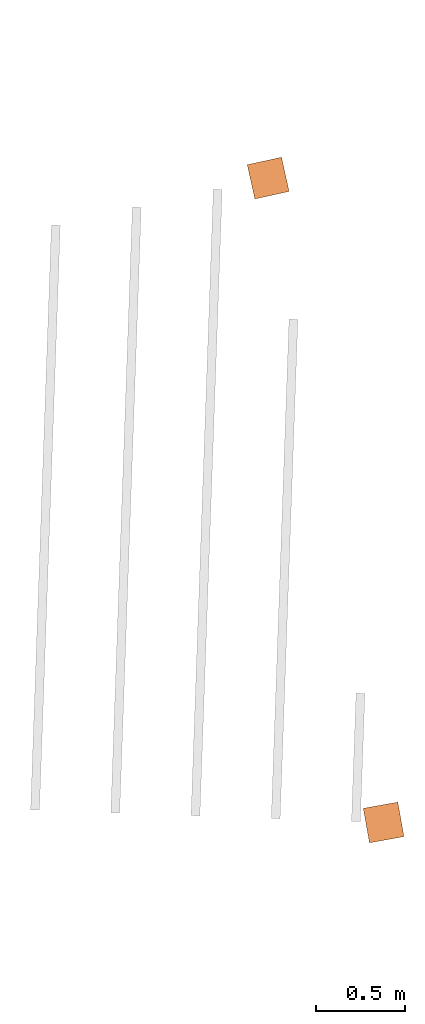
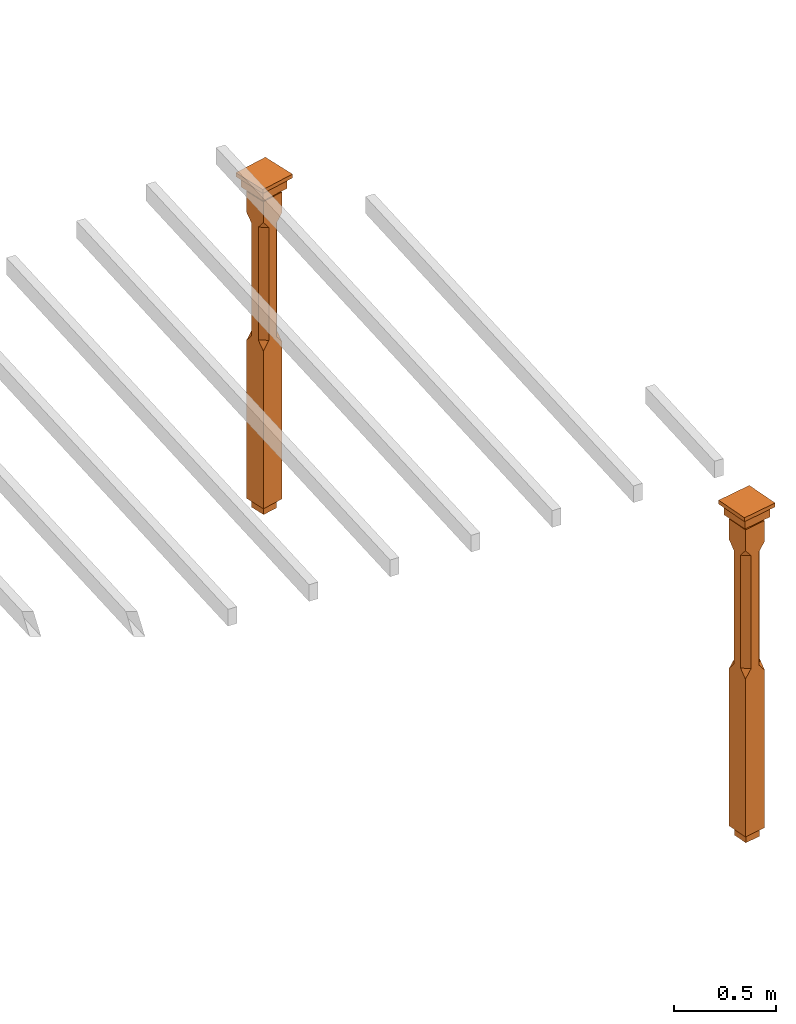
# One storey, part 11 of 11: 2 proxies.
"""IFC2X3 building model written with IfcOpenShell, lengths in metres."""

from ifc_helpers import new_model, si_unit, frame, origin, place, context, subcontext, project, spatial, faceted_brep, element, save


model = new_model("IFC2X3")

# Units and contexts
model_context = context("Model", 3, world=origin())
body_context = subcontext(model_context, "Body", "Model", "MODEL_VIEW")
ifc_project = project(units=[si_unit("PLANEANGLEUNIT", "RADIAN"), si_unit("MASSUNIT", "GRAM", prefix="KILO"), si_unit("FORCEUNIT", "NEWTON", prefix="KILO"), si_unit("LENGTHUNIT", "METRE")], contexts=[model_context])

# Site, building, storey
site_placement = place(None, origin())
site = spatial("IfcSite", under=ifc_project, at=site_placement, CompositionType="ELEMENT")
building_placement = place(None, origin())
building = spatial("IfcBuilding", under=site, at=building_placement, Name="Building plot-16", CompositionType="ELEMENT")
storey_placement = place(None, frame((0.0, 0.0, 9.0)))
storey = spatial("IfcBuildingStorey", under=building, at=storey_placement, Name="Floor 2", CompositionType="ELEMENT", Elevation=9.0)

# Proxies
proxy_1_placement = place(storey_placement, frame((101.80979404861, 32.9464222862981, 0.0), z_axis=(0.0, 0.0, 1.0), x_axis=(-0.17633948155404, 0.984329409925992, 0.0)))
element("IfcBuildingElementProxy", 1, at=proxy_1_placement, inside=storey, Name="pergola post", CompositionType="ELEMENT", context=body_context, shape_type="Brep", held_by="IfcProductRepresentation", body=[
    faceted_brep([(0.0246, -0.0615, 1.72), (0.0615, -0.0246, 1.72), (0.0615, -0.0615, 1.766667), (0.0615, -0.0246, 1.044444), (0.0246, -0.0615, 1.044444), (0.0615, 0.0246, 1.72), (0.0615, 0.0615, 1.766667), (-0.0246, -0.0615, 1.72), (-0.0615, -0.0615, 1.766667), (-0.0246, -0.0615, 1.044444), (0.0615, -0.0615, 0.997778), (0.0615, 0.0246, 1.044444), (0.0246, 0.0615, 1.72), (0.0615, 0.0615, 1.891111), (0.0615, -0.0615, 1.891111), (-0.0615, -0.0615, 1.891111), (-0.0615, -0.0246, 1.72), (-0.0615, -0.0246, 1.044444), (-0.0615, -0.0615, 0.997778), (0.0615, 0.0615, 0.997778), (0.0246, 0.0615, 1.044444), (-0.0246, 0.0615, 1.72), (-0.0615, 0.0615, 1.766667), (0.04305, 0.04305, 1.891111), (0.04305, -0.04305, 1.891111), (-0.0615, 0.0615, 1.891111), (-0.04305, -0.04305, 1.891111), (-0.0615, 0.0246, 1.72), (-0.0615, 0.0246, 1.044444), (0.0615, -0.0615, 0.053333), (-0.0615, -0.0615, 0.053333), (0.0615, 0.0615, 0.053333), (-0.0246, 0.0615, 1.044444), (-0.04305, 0.04305, 1.891111), (0.04305, 0.04305, 1.914444), (0.04305, -0.04305, 1.914444), (-0.04305, -0.04305, 1.914444), (-0.0615, 0.0615, 0.997778), (-0.0615, 0.0615, 0.053333), (-0.04305, -0.04305, 0.053333), (0.04305, -0.04305, 0.053333), (0.04305, 0.04305, 0.053333), (-0.04305, 0.04305, 1.914444), (0.07995, 0.07995, 1.914444), (0.07995, -0.07995, 1.914444), (-0.07995, -0.07995, 1.914444), (-0.04305, 0.04305, 0.053333), (-0.04305, -0.04305, 0.0), (0.04305, -0.04305, 0.0), (0.04305, 0.04305, 0.0), (-0.07995, 0.07995, 1.914444), (0.07995, 0.07995, 1.976667), (0.07995, -0.07995, 1.976667), (-0.07995, -0.07995, 1.976667), (-0.04305, 0.04305, 0.0), (-0.07995, 0.07995, 1.976667), (0.0984, 0.0984, 1.976667), (0.0984, -0.0984, 1.976667), (-0.0984, -0.0984, 1.976667), (-0.0984, 0.0984, 1.976667), (0.0984, 0.0984, 2.0), (0.0984, -0.0984, 2.0), (-0.0984, -0.0984, 2.0), (-0.0984, 0.0984, 2.0)], [[[0, 1, 2]], [[3, 1, 0, 4]], [[1, 5, 6, 2]], [[7, 0, 2, 8]], [[4, 0, 7, 9]], [[3, 4, 10]], [[1, 3, 11, 5]], [[5, 12, 6]], [[13, 14, 2, 6]], [[15, 8, 2, 14]], [[8, 16, 7]], [[9, 7, 16, 17]], [[9, 18, 10, 4]], [[3, 10, 19, 11]], [[20, 12, 5, 11]], [[21, 22, 6, 12]], [[14, 13, 23, 24]], [[13, 6, 22, 25]], [[25, 22, 8, 15]], [[26, 15, 14, 24]], [[16, 8, 22, 27]], [[27, 28, 17, 16]], [[17, 18, 9]], [[29, 10, 18, 30]], [[31, 19, 10, 29]], [[20, 11, 19]], [[12, 20, 32, 21]], [[21, 27, 22]], [[33, 23, 13, 25]], [[23, 34, 35, 24]], [[26, 33, 25, 15]], [[36, 26, 24, 35]], [[28, 27, 21, 32]], [[17, 28, 37, 18]], [[38, 30, 18, 37]], [[29, 30, 39, 40]], [[31, 38, 37, 19]], [[40, 41, 31, 29]], [[32, 20, 19, 37]], [[33, 42, 34, 23]], [[43, 44, 35, 34]], [[42, 33, 26, 36]], [[36, 35, 44, 45]], [[28, 32, 37]], [[46, 39, 30, 38]], [[39, 47, 48, 40]], [[46, 38, 31, 41]], [[49, 41, 40, 48]], [[43, 34, 42, 50]], [[43, 51, 52, 44]], [[45, 50, 42, 36]], [[53, 45, 44, 52]], [[46, 54, 47, 39]], [[54, 46, 41, 49]], [[50, 55, 51, 43]], [[56, 57, 52, 51]], [[55, 50, 45, 53]], [[53, 52, 57, 58]], [[56, 51, 55, 59]], [[56, 60, 61, 57]], [[58, 59, 55, 53]], [[62, 58, 57, 61]], [[59, 63, 60, 56]], [[63, 62, 61, 60]], [[58, 62, 63, 59]], [[47, 54, 49, 48]]]),
])
proxy_2_placement = place(storey_placement, frame((101.162607181796, 36.5590282728232, 0.0), z_axis=(0.0, 0.0, 1.0), x_axis=(-0.976282093745437, -0.216502363571453, 0.0)))
element("IfcBuildingElementProxy", 2, at=proxy_2_placement, inside=storey, Name="pergola post", CompositionType="ELEMENT", context=body_context, shape_type="Brep", held_by="IfcProductRepresentation", body=[
    faceted_brep([(0.0246, -0.0615, 1.72), (0.0615, -0.0246, 1.72), (0.0615, -0.0615, 1.766667), (0.0615, -0.0246, 1.044444), (0.0246, -0.0615, 1.044444), (0.0615, 0.0246, 1.72), (0.0615, 0.0615, 1.766667), (-0.0246, -0.0615, 1.72), (-0.0615, -0.0615, 1.766667), (-0.0246, -0.0615, 1.044444), (0.0615, -0.0615, 0.997778), (0.0615, 0.0246, 1.044444), (0.0246, 0.0615, 1.72), (0.0615, 0.0615, 1.891111), (0.0615, -0.0615, 1.891111), (-0.0615, -0.0615, 1.891111), (-0.0615, -0.0246, 1.72), (-0.0615, -0.0246, 1.044444), (-0.0615, -0.0615, 0.997778), (0.0615, 0.0615, 0.997778), (0.0246, 0.0615, 1.044444), (-0.0246, 0.0615, 1.72), (-0.0615, 0.0615, 1.766667), (0.04305, 0.04305, 1.891111), (0.04305, -0.04305, 1.891111), (-0.0615, 0.0615, 1.891111), (-0.04305, -0.04305, 1.891111), (-0.0615, 0.0246, 1.72), (-0.0615, 0.0246, 1.044444), (0.0615, -0.0615, 0.053333), (-0.0615, -0.0615, 0.053333), (0.0615, 0.0615, 0.053333), (-0.0246, 0.0615, 1.044444), (-0.04305, 0.04305, 1.891111), (0.04305, 0.04305, 1.914444), (0.04305, -0.04305, 1.914444), (-0.04305, -0.04305, 1.914444), (-0.0615, 0.0615, 0.997778), (-0.0615, 0.0615, 0.053333), (-0.04305, -0.04305, 0.053333), (0.04305, -0.04305, 0.053333), (0.04305, 0.04305, 0.053333), (-0.04305, 0.04305, 1.914444), (0.07995, 0.07995, 1.914444), (0.07995, -0.07995, 1.914444), (-0.07995, -0.07995, 1.914444), (-0.04305, 0.04305, 0.053333), (-0.04305, -0.04305, 0.0), (0.04305, -0.04305, 0.0), (0.04305, 0.04305, 0.0), (-0.07995, 0.07995, 1.914444), (0.07995, 0.07995, 1.976667), (0.07995, -0.07995, 1.976667), (-0.07995, -0.07995, 1.976667), (-0.04305, 0.04305, 0.0), (-0.07995, 0.07995, 1.976667), (0.0984, 0.0984, 1.976667), (0.0984, -0.0984, 1.976667), (-0.0984, -0.0984, 1.976667), (-0.0984, 0.0984, 1.976667), (0.0984, 0.0984, 2.0), (0.0984, -0.0984, 2.0), (-0.0984, -0.0984, 2.0), (-0.0984, 0.0984, 2.0)], [[[0, 1, 2]], [[3, 1, 0, 4]], [[1, 5, 6, 2]], [[7, 0, 2, 8]], [[4, 0, 7, 9]], [[3, 4, 10]], [[1, 3, 11, 5]], [[5, 12, 6]], [[13, 14, 2, 6]], [[15, 8, 2, 14]], [[8, 16, 7]], [[9, 7, 16, 17]], [[9, 18, 10, 4]], [[3, 10, 19, 11]], [[20, 12, 5, 11]], [[21, 22, 6, 12]], [[14, 13, 23, 24]], [[13, 6, 22, 25]], [[25, 22, 8, 15]], [[26, 15, 14, 24]], [[16, 8, 22, 27]], [[27, 28, 17, 16]], [[17, 18, 9]], [[29, 10, 18, 30]], [[31, 19, 10, 29]], [[20, 11, 19]], [[12, 20, 32, 21]], [[21, 27, 22]], [[33, 23, 13, 25]], [[23, 34, 35, 24]], [[26, 33, 25, 15]], [[36, 26, 24, 35]], [[28, 27, 21, 32]], [[17, 28, 37, 18]], [[38, 30, 18, 37]], [[29, 30, 39, 40]], [[31, 38, 37, 19]], [[40, 41, 31, 29]], [[32, 20, 19, 37]], [[33, 42, 34, 23]], [[43, 44, 35, 34]], [[42, 33, 26, 36]], [[36, 35, 44, 45]], [[28, 32, 37]], [[46, 39, 30, 38]], [[39, 47, 48, 40]], [[46, 38, 31, 41]], [[49, 41, 40, 48]], [[43, 34, 42, 50]], [[43, 51, 52, 44]], [[45, 50, 42, 36]], [[53, 45, 44, 52]], [[46, 54, 47, 39]], [[54, 46, 41, 49]], [[50, 55, 51, 43]], [[56, 57, 52, 51]], [[55, 50, 45, 53]], [[53, 52, 57, 58]], [[56, 51, 55, 59]], [[56, 60, 61, 57]], [[58, 59, 55, 53]], [[62, 58, 57, 61]], [[59, 63, 60, 56]], [[63, 62, 61, 60]], [[58, 62, 63, 59]], [[47, 54, 49, 48]]]),
])

save(model, "model.ifc")
